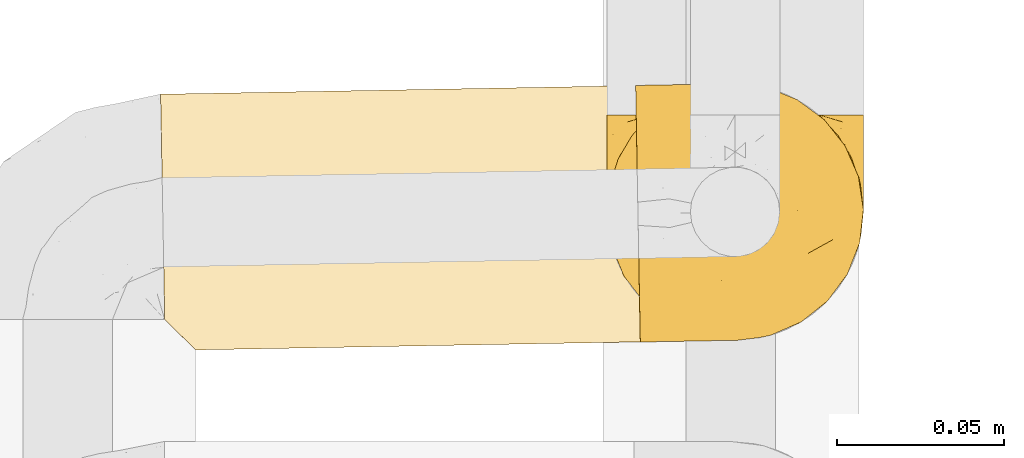
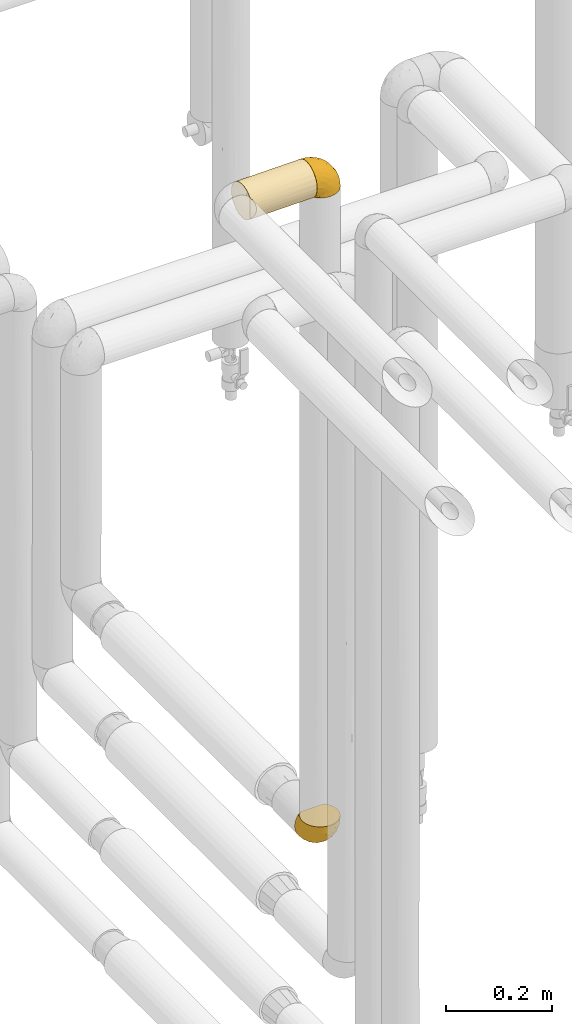
# One storey, part 71 of 827: 3 coverings.
"""IFC2X3 building model written with IfcOpenShell, lengths in millimetres."""

from ifc_helpers import new_model, entity, si_unit, converted_unit, derived_unit, direction, frame, origin, place, context, subcontext, project, spatial, faceted_brep, element, save


model = new_model("IFC2X3")

# Units and contexts
model_context = context("Model", 3, precision=0.01, world=origin(), true_north=direction((6.12303176911189e-17, 1.0)))
body_context = subcontext(model_context, "Body", "Model", "MODEL_VIEW")
ifc_project = project(units=[si_unit("LENGTHUNIT", "METRE", prefix="MILLI"), si_unit("AREAUNIT", "SQUARE_METRE"), si_unit("VOLUMEUNIT", "CUBIC_METRE"), converted_unit("PLANEANGLEUNIT", "DEGREE", entity("IfcRatioMeasure", 0.0174532925199433), si_unit("PLANEANGLEUNIT", "RADIAN"), dimensions=[0, 0, 0, 0, 0, 0, 0]), si_unit("MASSUNIT", "GRAM", prefix="KILO"), derived_unit("MASSDENSITYUNIT", [(si_unit("MASSUNIT", "GRAM", prefix="KILO"), 1), (si_unit("LENGTHUNIT", "METRE"), -3)]), derived_unit("MOMENTOFINERTIAUNIT", [(si_unit("LENGTHUNIT", "METRE"), 4)]), si_unit("TIMEUNIT", "SECOND"), si_unit("FREQUENCYUNIT", "HERTZ"), si_unit("THERMODYNAMICTEMPERATUREUNIT", "DEGREE_CELSIUS"), derived_unit("THERMALTRANSMITTANCEUNIT", [(si_unit("MASSUNIT", "GRAM", prefix="KILO"), 1), (si_unit("THERMODYNAMICTEMPERATUREUNIT", "KELVIN"), -1), (si_unit("TIMEUNIT", "SECOND"), -3)]), derived_unit("VOLUMETRICFLOWRATEUNIT", [(si_unit("LENGTHUNIT", "METRE"), 3), (si_unit("TIMEUNIT", "SECOND"), -1)]), derived_unit("MASSFLOWRATEUNIT", [(si_unit("MASSUNIT", "GRAM", prefix="KILO"), 1), (si_unit("TIMEUNIT", "SECOND"), -1)]), derived_unit("ROTATIONALFREQUENCYUNIT", [(si_unit("TIMEUNIT", "SECOND"), -1)]), si_unit("ELECTRICCURRENTUNIT", "AMPERE"), si_unit("ELECTRICVOLTAGEUNIT", "VOLT"), si_unit("POWERUNIT", "WATT"), si_unit("FORCEUNIT", "NEWTON", prefix="KILO"), si_unit("ILLUMINANCEUNIT", "LUX"), si_unit("LUMINOUSFLUXUNIT", "LUMEN"), si_unit("LUMINOUSINTENSITYUNIT", "CANDELA"), derived_unit("USERDEFINED", [(si_unit("MASSUNIT", "GRAM", prefix="KILO"), -1), (si_unit("LENGTHUNIT", "METRE"), -2), (si_unit("TIMEUNIT", "SECOND"), 3), (si_unit("LUMINOUSFLUXUNIT", "LUMEN"), 1)]), derived_unit("LINEARVELOCITYUNIT", [(si_unit("LENGTHUNIT", "METRE"), 1), (si_unit("TIMEUNIT", "SECOND"), -1)]), si_unit("PRESSUREUNIT", "PASCAL"), derived_unit("USERDEFINED", [(si_unit("LENGTHUNIT", "METRE"), -2), (si_unit("MASSUNIT", "GRAM", prefix="KILO"), 1), (si_unit("TIMEUNIT", "SECOND"), -2)]), derived_unit("LINEARFORCEUNIT", [(si_unit("MASSUNIT", "GRAM", prefix="KILO"), 1), (si_unit("LENGTHUNIT", "METRE"), 1), (si_unit("TIMEUNIT", "SECOND"), -2), (si_unit("LENGTHUNIT", "METRE"), -1)]), derived_unit("PLANARFORCEUNIT", [(si_unit("MASSUNIT", "GRAM", prefix="KILO"), 1), (si_unit("LENGTHUNIT", "METRE"), 1), (si_unit("TIMEUNIT", "SECOND"), -2), (si_unit("LENGTHUNIT", "METRE"), -2)])], contexts=[model_context])

# Site, building, storey
site_placement = place(None, origin())
site = spatial("IfcSite", under=ifc_project, at=site_placement, CompositionType="ELEMENT")
building_placement = place(site_placement, origin())
building = spatial("IfcBuilding", under=site, at=building_placement, CompositionType="ELEMENT")
storey_placement = place(building_placement, frame((0.0, 0.0, 28200.0)))
storey = spatial("IfcBuildingStorey", under=building, at=storey_placement, Name="08", CompositionType="ELEMENT", Elevation=28200.0)

# Coverings
covering_1_placement = place(storey_placement, frame((17888.48, 10823.39, 1308.2)))
element("IfcCovering", 1, at=covering_1_placement, inside=storey, Name=":ADSK_", ObjectType=":ADSK_", PredefinedType="INSULATION", context=body_context, shape_type="Brep", body=[
    faceted_brep([(74.68, 69.15, 23.36), (70.1, 69.15, 16.07), (64.01, 69.15, 9.98), (56.72, 69.15, 5.4), (48.6, 69.15, 2.56), (40.05, 69.15, 1.6), (31.49, 69.15, 2.56), (23.36, 69.15, 5.41), (16.07, 69.15, 9.99), (9.98, 69.15, 16.08), (5.4, 69.15, 23.37), (2.56, 69.15, 31.49), (1.6, 69.15, 40.05), (2.46, 69.15, 48.15), (5.01, 69.15, 55.88), (9.13, 69.15, 62.9), (14.62, 69.15, 68.89), (16.82, 69.15, 68.89), (18.56, 69.15, 68.89), (20.52, 69.15, 68.89), (22.49, 69.15, 68.89), (24.46, 69.15, 68.89), (26.42, 69.15, 68.89), (28.39, 69.15, 68.89), (30.36, 69.15, 68.89), (32.55, 69.15, 68.89), (34.75, 69.15, 68.89), (36.94, 69.15, 68.89), (39.13, 69.15, 68.89), (41.33, 69.15, 68.89), (43.52, 69.15, 68.89), (45.72, 69.15, 68.89), (47.91, 69.15, 68.89), (50.11, 69.15, 68.89), (52.3, 69.15, 68.89), (54.49, 69.15, 68.89), (56.69, 69.15, 68.89), (58.88, 69.15, 68.89), (61.08, 69.15, 68.89), (63.27, 69.15, 68.89), (65.47, 69.15, 68.89), (70.97, 69.15, 62.89), (75.09, 69.15, 55.86), (77.64, 69.15, 48.13), (78.5, 69.15, 40.05), (77.53, 69.15, 31.49), (14.62, 68.89, 69.15), (9.12, 62.89, 69.15), (5.0, 55.87, 69.15), (2.46, 48.14, 69.15), (1.6, 40.05, 69.15), (2.91, 30.09, 69.15), (6.75, 20.82, 69.15), (12.86, 12.86, 69.15), (20.82, 6.75, 69.15), (30.09, 2.91, 69.15), (40.05, 1.6, 69.15), (50.0, 2.91, 69.15), (59.27, 6.75, 69.15), (67.23, 12.86, 69.15), (73.34, 20.82, 69.15), (77.19, 30.09, 69.15), (78.5, 40.05, 69.15), (77.63, 48.14, 69.15), (75.09, 55.87, 69.15), (70.97, 62.89, 69.15), (65.47, 68.89, 69.15), (63.27, 68.89, 69.15), (62.29, 68.89, 69.15), (60.7, 68.89, 69.15), (59.11, 68.89, 69.15), (57.52, 68.89, 69.15), (55.93, 68.89, 69.15), (54.34, 68.89, 69.15), (52.76, 68.89, 69.15), (51.17, 68.89, 69.15), (49.58, 68.89, 69.15), (47.99, 68.89, 69.15), (46.4, 68.89, 69.15), (44.81, 68.89, 69.15), (43.22, 68.89, 69.15), (41.63, 68.89, 69.15), (40.05, 68.89, 69.15), (38.46, 68.89, 69.15), (36.87, 68.89, 69.15), (35.28, 68.89, 69.15), (33.69, 68.89, 69.15), (32.1, 68.89, 69.15), (30.51, 68.89, 69.15), (28.92, 68.89, 69.15), (27.33, 68.89, 69.15), (25.37, 68.89, 69.15), (23.4, 68.89, 69.15), (21.21, 68.89, 69.15), (19.01, 68.89, 69.15), (16.82, 68.89, 69.15), (42.32, 68.97, 68.96), (44.02, 68.96, 68.97), (47.13, 68.97, 68.97), (48.74, 68.97, 68.97), (23.57, 68.98, 68.95), (25.13, 68.97, 68.96), (61.34, 68.96, 68.98), (22.02, 68.96, 68.97), (29.72, 68.96, 68.97), (56.73, 68.96, 68.98), (55.14, 68.96, 68.97), (37.66, 68.96, 68.97), (64.12, 69.0, 68.94), (28.13, 68.96, 68.98), (26.62, 68.96, 68.98), (31.46, 68.97, 68.96), (16.16, 68.96, 68.97), (39.16, 68.96, 68.98), (50.37, 68.96, 68.98), (17.69, 68.97, 68.97), (19.17, 68.97, 68.96), (62.78, 68.97, 68.97), (58.35, 68.96, 68.97), (45.53, 68.96, 68.98), (59.91, 68.97, 68.96), (65.47, 68.97, 68.97), (65.47, 69.02, 68.94), (65.47, 69.08, 68.92), (14.62, 68.97, 68.97), (14.62, 68.94, 69.02), (14.62, 68.92, 69.08), (20.59, 68.96, 68.98), (32.99, 68.96, 68.97), (34.48, 68.95, 68.98), (51.91, 68.96, 68.97), (65.47, 68.92, 69.08), (65.47, 68.94, 69.02), (53.48, 68.98, 68.96), (14.62, 69.08, 68.92), (14.62, 69.02, 68.94), (40.77, 68.96, 68.97), (35.97, 68.97, 68.96), (7.84, 61.33, 67.02), (3.53, 53.1, 63.33), (8.32, 63.33, 64.61), (2.19, 55.53, 51.4), (3.53, 63.33, 53.1), (1.6, 54.6, 43.94), (1.6, 41.99, 61.87), (4.57, 57.07, 61.54), (3.96, 57.95, 57.95), (2.28, 51.56, 56.12), (1.6, 41.58, 63.4), (7.69, 61.7, 65.41), (8.32, 65.0, 63.04), (7.84, 67.02, 61.33), (1.6, 61.87, 41.99), (1.6, 49.27, 49.27), (1.6, 43.94, 54.6), (4.34, 61.21, 56.6), (1.6, 63.4, 41.58), (29.63, 33.11, 13.72), (27.34, 52.82, 5.82), (40.05, 43.3, 6.74), (2.39, 33.73, 58.82), (2.43, 36.52, 51.58), (9.07, 24.87, 42.09), (16.64, 14.17, 46.12), (9.54, 18.43, 55.56), (4.52, 28.67, 52.38), (4.52, 26.0, 61.54), (7.49, 49.25, 23.76), (7.49, 59.72, 20.5), (12.85, 55.1, 14.64), (2.35, 44.72, 41.77), (22.66, 34.15, 16.28), (32.9, 5.25, 49.4), (25.33, 6.75, 52.34), (40.05, 55.54, 4.3), (16.64, 10.47, 58.67), (19.99, 25.49, 25.26), (16.37, 35.53, 20.17), (3.26, 48.22, 34.7), (3.75, 58.71, 28.67), (19.58, 57.42, 8.62), (7.5, 34.84, 33.37), (4.04, 36.87, 41.35), (13.94, 45.01, 17.15), (19.58, 44.4, 12.68), (28.21, 23.96, 21.47), (24.75, 11.2, 41.11), (31.42, 10.56, 37.53), (26.2, 16.81, 30.64), (33.36, 17.38, 26.66), (40.05, 21.38, 21.38), (40.05, 32.34, 14.06), (40.05, 4.3, 55.54), (16.14, 20.65, 35.17), (12.85, 29.66, 29.04), (10.47, 39.6, 24.34), (6.49, 42.55, 29.33), (40.05, 6.74, 43.3), (40.05, 14.06, 32.34), (75.57, 26.84, 57.75), (47.37, 5.28, 49.41), (52.91, 18.52, 27.85), (50.46, 33.13, 13.7), (67.23, 55.1, 14.63), (60.5, 57.43, 8.61), (70.55, 20.72, 48.85), (63.45, 11.46, 54.13), (62.61, 17.69, 37.84), (72.6, 49.26, 23.75), (72.6, 59.73, 20.49), (76.34, 58.71, 28.66), (59.34, 29.72, 20.83), (77.76, 35.35, 55.15), (78.5, 43.94, 54.6), (78.5, 41.99, 61.87), (78.5, 63.4, 41.58), (53.16, 4.93, 57.58), (70.55, 17.46, 59.91), (48.88, 10.94, 36.94), (54.76, 8.92, 45.72), (52.74, 52.83, 5.82), (71.93, 29.34, 37.91), (75.79, 30.26, 50.18), (60.5, 44.4, 12.67), (77.86, 39.06, 49.29), (77.64, 43.06, 42.64), (78.5, 54.6, 43.94), (78.5, 49.27, 49.27), (67.23, 42.69, 19.45), (76.82, 48.2, 34.7), (78.5, 61.87, 41.99), (77.8, 33.44, 62.29), (67.23, 29.67, 29.01), (73.2, 38.5, 31.47), (67.66, 23.35, 37.18), (75.99, 34.97, 43.45), (76.57, 53.1, 63.33), (73.21, 59.68, 67.23), (71.93, 62.19, 66.07), (71.07, 64.11, 65.22), (75.09, 57.97, 61.99), (76.13, 57.95, 57.95), (76.57, 63.33, 53.09), (77.69, 51.77, 56.84), (72.26, 67.02, 61.33), (71.77, 64.98, 63.06), (77.9, 55.53, 51.41), (75.75, 61.22, 56.61)], [[[0, 1, 2, 3, 4, 5, 6, 7, 8, 9, 10, 11, 12, 13, 14, 15, 16, 17, 18, 19, 20, 21, 22, 23, 24, 25, 26, 27, 28, 29, 30, 31, 32, 33, 34, 35, 36, 37, 38, 39, 40, 41, 42, 43, 44, 45]], [[46, 47, 48, 49, 50, 51, 52, 53, 54, 55, 56, 57, 58, 59, 60, 61, 62, 63, 64, 65, 66, 67, 68, 69, 70, 71, 72, 73, 74, 75, 76, 77, 78, 79, 80, 81, 82, 83, 84, 85, 86, 87, 88, 89, 90, 91, 92, 93, 94, 95]], [[96, 97, 30]], [[98, 77, 99]], [[100, 101, 21]], [[69, 68, 102]], [[20, 19, 103]], [[24, 23, 104]], [[20, 103, 100]], [[72, 105, 106]], [[84, 83, 107]], [[89, 88, 104]], [[108, 67, 66]], [[109, 110, 90]], [[111, 25, 24]], [[112, 17, 16]], [[82, 113, 83]], [[109, 23, 22]], [[114, 76, 75]], [[105, 36, 106]], [[104, 111, 24]], [[18, 115, 116]], [[97, 96, 80]], [[67, 108, 117]], [[105, 71, 118]], [[31, 97, 119]], [[102, 120, 69]], [[108, 121, 122, 123, 40]], [[112, 95, 115]], [[17, 115, 18]], [[94, 116, 115]], [[117, 68, 67]], [[38, 117, 39]], [[112, 124, 125, 126, 46]], [[17, 112, 115]], [[70, 120, 118]], [[39, 117, 108]], [[120, 38, 37]], [[120, 37, 118]], [[120, 70, 69]], [[116, 94, 127]], [[128, 86, 129]], [[117, 38, 102]], [[74, 130, 75]], [[99, 33, 32]], [[115, 95, 94]], [[39, 108, 40]], [[108, 66, 131, 132, 121]], [[105, 72, 71]], [[118, 37, 36]], [[71, 70, 118]], [[35, 106, 36]], [[36, 105, 118]], [[35, 133, 106]], [[74, 73, 133]], [[106, 133, 73]], [[99, 114, 33]], [[133, 35, 34]], [[73, 72, 106]], [[95, 112, 46]], [[112, 16, 134, 135, 124]], [[130, 114, 75]], [[99, 76, 114]], [[114, 130, 33]], [[34, 33, 130]], [[78, 77, 98]], [[98, 119, 78]], [[130, 133, 34]], [[133, 130, 74]], [[79, 97, 80]], [[98, 99, 32]], [[98, 32, 31]], [[77, 76, 99]], [[97, 79, 119]], [[136, 96, 29]], [[30, 97, 31]], [[136, 29, 28]], [[81, 80, 96]], [[29, 96, 30]], [[31, 119, 98]], [[119, 79, 78]], [[96, 136, 81]], [[82, 81, 136]], [[113, 107, 83]], [[84, 107, 137]], [[107, 27, 137]], [[113, 28, 107]], [[27, 107, 28]], [[85, 84, 137]], [[137, 27, 26]], [[113, 136, 28]], [[136, 113, 82]], [[109, 89, 104]], [[86, 85, 129]], [[89, 109, 90]], [[111, 87, 128]], [[26, 129, 137]], [[88, 111, 104]], [[25, 111, 128]], [[22, 110, 109]], [[23, 109, 104]], [[110, 91, 90]], [[100, 92, 101]], [[110, 22, 101]], [[91, 110, 101]], [[116, 19, 18]], [[111, 88, 87]], [[127, 103, 19]], [[25, 128, 26]], [[86, 128, 87]], [[128, 129, 26]], [[137, 129, 85]], [[120, 102, 38]], [[117, 102, 68]], [[91, 101, 92]], [[21, 101, 22]], [[93, 92, 103]], [[100, 21, 20]], [[100, 103, 92]], [[127, 93, 103]], [[93, 127, 94]], [[116, 127, 19]], [[126, 138, 47]], [[48, 138, 139]], [[140, 125, 124]], [[141, 142, 143]], [[144, 49, 139]], [[145, 140, 146]], [[48, 139, 49]], [[139, 145, 147]], [[49, 144, 148, 50]], [[126, 125, 149]], [[14, 13, 142]], [[150, 146, 140]], [[149, 140, 145]], [[151, 150, 135]], [[151, 14, 142]], [[16, 15, 134]], [[13, 152, 142]], [[124, 150, 140]], [[141, 143, 153]], [[14, 151, 15]], [[15, 151, 134]], [[47, 46, 126]], [[139, 154, 144]], [[138, 48, 47]], [[125, 140, 149]], [[135, 134, 151]], [[146, 155, 141]], [[145, 146, 147]], [[149, 139, 138]], [[147, 153, 154]], [[147, 146, 141]], [[139, 147, 154]], [[139, 149, 145]], [[149, 138, 126]], [[147, 141, 153]], [[146, 150, 155]], [[151, 155, 150]], [[142, 141, 155]], [[13, 12, 156, 152]], [[152, 143, 142]], [[151, 142, 155]], [[150, 124, 135]], [[157, 158, 159]], [[160, 154, 161]], [[162, 163, 164]], [[165, 166, 160]], [[167, 168, 169]], [[153, 170, 161]], [[156, 12, 11]], [[158, 157, 171]], [[172, 55, 173]], [[158, 6, 174]], [[175, 54, 53]], [[52, 166, 164]], [[52, 164, 53]], [[54, 175, 173]], [[166, 52, 51]], [[176, 177, 171]], [[178, 143, 179]], [[156, 11, 179]], [[8, 7, 180]], [[169, 9, 8]], [[179, 143, 152, 156]], [[179, 11, 10]], [[168, 179, 10]], [[181, 162, 182]], [[179, 167, 178]], [[183, 184, 177]], [[183, 169, 184]], [[176, 171, 185]], [[172, 186, 187]], [[158, 7, 6]], [[159, 158, 174]], [[184, 180, 158]], [[54, 173, 55]], [[180, 169, 8]], [[188, 189, 187]], [[9, 168, 10]], [[186, 188, 187]], [[190, 157, 159, 191]], [[55, 172, 192]], [[176, 193, 194]], [[161, 170, 182]], [[162, 164, 165]], [[175, 164, 163]], [[51, 50, 148]], [[167, 195, 196]], [[178, 182, 170]], [[6, 5, 174]], [[158, 180, 7]], [[169, 180, 184]], [[169, 168, 9]], [[179, 168, 167]], [[182, 162, 165]], [[162, 194, 193]], [[161, 165, 160]], [[195, 181, 196]], [[192, 172, 197]], [[192, 56, 55]], [[189, 190, 198]], [[198, 197, 187]], [[172, 187, 197]], [[185, 189, 188]], [[198, 187, 189]], [[186, 172, 173]], [[173, 163, 186]], [[193, 186, 163]], [[176, 185, 188]], [[185, 157, 190]], [[188, 186, 193]], [[177, 176, 194]], [[188, 193, 176]], [[162, 193, 163]], [[195, 177, 194]], [[171, 177, 184]], [[181, 195, 194]], [[183, 167, 169]], [[162, 181, 194]], [[196, 182, 178]], [[158, 171, 184]], [[171, 157, 185]], [[177, 195, 183]], [[167, 183, 195]], [[182, 196, 181]], [[178, 170, 143]], [[178, 167, 196]], [[164, 175, 53]], [[173, 175, 163]], [[160, 51, 148]], [[164, 166, 165]], [[51, 160, 166]], [[160, 148, 144, 154]], [[153, 161, 154]], [[182, 165, 161]], [[190, 189, 185]], [[143, 170, 153]], [[60, 199, 61]], [[197, 200, 192]], [[201, 190, 202]], [[200, 57, 192]], [[203, 204, 2]], [[205, 206, 207]], [[208, 209, 210]], [[211, 207, 201]], [[212, 213, 214]], [[45, 215, 210]], [[216, 206, 58]], [[45, 44, 215]], [[59, 217, 60]], [[60, 217, 199]], [[0, 45, 210]], [[218, 201, 219]], [[202, 159, 220]], [[205, 221, 222]], [[223, 204, 203]], [[1, 203, 2]], [[57, 200, 216]], [[220, 3, 204]], [[220, 174, 4]], [[1, 0, 209]], [[212, 224, 213]], [[225, 226, 227]], [[228, 223, 203]], [[208, 210, 229]], [[210, 226, 229]], [[3, 220, 4]], [[58, 206, 59]], [[209, 203, 1]], [[202, 220, 223]], [[228, 203, 208]], [[202, 211, 201]], [[3, 2, 204]], [[202, 190, 191, 159]], [[210, 215, 230, 226]], [[199, 212, 231]], [[232, 233, 221]], [[233, 208, 229]], [[207, 206, 219]], [[217, 206, 205]], [[227, 224, 225]], [[233, 232, 228]], [[201, 207, 219]], [[234, 232, 221]], [[218, 219, 200]], [[202, 223, 211]], [[174, 220, 159]], [[174, 5, 4]], [[61, 231, 62]], [[220, 204, 223]], [[210, 209, 0]], [[203, 209, 208]], [[225, 233, 229]], [[224, 227, 213]], [[221, 233, 235]], [[57, 56, 192]], [[198, 218, 197]], [[200, 219, 216]], [[201, 198, 190]], [[197, 218, 200]], [[198, 201, 218]], [[206, 216, 219]], [[58, 57, 216]], [[231, 212, 214]], [[222, 212, 199]], [[228, 211, 223]], [[207, 211, 232]], [[62, 231, 214]], [[199, 231, 61]], [[233, 228, 208]], [[211, 228, 232]], [[222, 221, 235]], [[234, 205, 207]], [[206, 217, 59]], [[199, 217, 205]], [[205, 222, 199]], [[224, 222, 235]], [[222, 224, 212]], [[224, 235, 225]], [[233, 225, 235]], [[226, 225, 229]], [[205, 234, 221]], [[207, 232, 234]], [[63, 214, 236]], [[214, 213, 236]], [[214, 63, 62]], [[237, 236, 238]], [[238, 132, 131]], [[236, 237, 64]], [[239, 240, 241]], [[63, 236, 64]], [[131, 66, 65]], [[237, 131, 65]], [[242, 230, 43]], [[237, 65, 64]], [[239, 121, 132]], [[42, 242, 43]], [[241, 240, 243]], [[41, 123, 244]], [[43, 230, 215, 44]], [[244, 122, 245]], [[227, 246, 243]], [[241, 243, 246]], [[121, 239, 245]], [[41, 40, 123]], [[132, 238, 239]], [[244, 42, 41]], [[131, 237, 238]], [[240, 239, 238]], [[245, 239, 241]], [[247, 241, 246]], [[247, 244, 245]], [[238, 236, 240]], [[243, 236, 213]], [[236, 243, 240]], [[226, 246, 227]], [[243, 213, 227]], [[226, 242, 246]], [[241, 247, 245]], [[246, 242, 247]], [[244, 247, 242]], [[242, 226, 230]], [[42, 244, 242]], [[122, 244, 123]], [[122, 121, 245]]]),
])
covering_2_placement = place(storey_placement, frame((17754.8, 10820.5, 2810.11)))
element("IfcCovering", 2, at=covering_2_placement, inside=storey, Name=":ADSK_", ObjectType=":ADSK_", PredefinedType="INSULATION", context=body_context, shape_type="Brep", body=[
    faceted_brep([(143.99, 77.31, 23.98), (143.95, 79.92, 31.79), (143.93, 80.8, 39.99), (143.96, 79.5, 49.93), (144.03, 75.66, 59.19), (144.14, 69.56, 67.15), (144.29, 61.61, 73.25), (144.45, 52.35, 77.09), (144.64, 42.41, 78.39), (144.82, 32.47, 77.09), (144.98, 23.21, 73.25), (145.13, 15.26, 67.15), (145.24, 9.16, 59.19), (145.31, 5.32, 49.93), (145.33, 4.02, 39.99), (145.31, 4.9, 31.79), (145.26, 7.51, 23.98), (145.18, 11.73, 16.91), (145.08, 17.36, 10.89), (144.17, 67.46, 10.89), (144.07, 73.09, 16.91), (1.62, 76.91, 30.07), (1.69, 73.07, 20.81), (1.8, 66.97, 12.86), (1.94, 59.02, 6.76), (2.11, 49.76, 2.92), (2.29, 39.82, 1.61), (2.44, 31.62, 2.5), (2.58, 23.81, 5.11), (2.71, 16.74, 9.33), (2.82, 10.73, 14.96), (2.83, 10.73, 65.07), (2.72, 16.74, 70.7), (2.59, 23.81, 74.91), (2.45, 31.62, 77.53), (2.3, 39.82, 78.41), (2.12, 49.76, 77.1), (1.95, 59.02, 73.27), (1.8, 66.97, 67.17), (1.69, 73.07, 59.21), (1.62, 76.91, 49.95), (1.6, 78.22, 40.01), (11.52, 2.19, 33.22), (9.72, 3.95, 26.65), (6.79, 6.83, 20.49), (12.12, 1.6, 40.01), (141.01, 22.83, 6.92), (137.97, 28.92, 3.99), (136.06, 35.47, 2.2), (135.33, 42.24, 1.6), (135.81, 49.04, 2.2), (137.48, 55.65, 3.99), (140.3, 61.85, 6.92), (6.8, 6.83, 59.53), (9.72, 3.95, 53.37), (11.52, 2.19, 46.8)], [[[0, 1, 2, 3, 4, 5, 6, 7, 8, 9, 10, 11, 12, 13, 14, 15, 16, 17, 18, 19, 20]], [[21, 22, 23, 24, 25, 26, 27, 28, 29, 30, 31, 32, 33, 34, 35, 36, 37, 38, 39, 40, 41]], [[42, 43, 15]], [[44, 30, 17]], [[43, 44, 16]], [[45, 42, 14]], [[15, 14, 42]], [[43, 16, 15]], [[44, 17, 16]], [[30, 18, 17]], [[46, 29, 28]], [[47, 28, 27]], [[48, 27, 26]], [[46, 18, 29]], [[48, 47, 27]], [[49, 48, 26]], [[46, 28, 47]], [[29, 18, 30]], [[50, 49, 26]], [[50, 26, 25]], [[51, 25, 24]], [[51, 50, 25]], [[19, 52, 24]], [[51, 24, 52]], [[24, 23, 19]], [[20, 23, 22]], [[0, 22, 21]], [[1, 21, 41]], [[20, 22, 0]], [[0, 21, 1]], [[41, 2, 1]], [[23, 20, 19]], [[3, 2, 41, 40]], [[4, 3, 40, 39]], [[39, 38, 5, 4]], [[7, 6, 37, 36]], [[8, 7, 36, 35]], [[38, 37, 6, 5]], [[8, 35, 34]], [[9, 34, 33]], [[10, 33, 32]], [[8, 34, 9]], [[9, 33, 10]], [[32, 11, 10]], [[32, 31, 11]], [[31, 53, 12]], [[54, 55, 13]], [[53, 54, 12]], [[12, 54, 13]], [[14, 13, 55]], [[45, 14, 55]], [[31, 12, 11]], [[48, 49, 50, 51, 52, 19, 18, 46, 47]], [[30, 44, 43, 42, 45, 55, 54, 53, 31]]]),
])
covering_3_placement = place(storey_placement, frame((17897.14, 10822.87, 2819.41)))
element("IfcCovering", 3, at=covering_3_placement, inside=storey, Name=":ADSK_", ObjectType=":ADSK_", PredefinedType="INSULATION", context=body_context, shape_type="Brep", body=[
    faceted_brep([(2.93, 5.41, 47.38), (2.84, 9.99, 54.67), (2.73, 16.08, 60.76), (2.6, 23.36, 65.34), (2.45, 31.49, 68.18), (2.3, 40.04, 69.15), (2.14, 48.6, 68.18), (2.0, 56.73, 65.33), (1.86, 64.01, 60.75), (1.75, 70.1, 54.66), (1.67, 74.68, 47.37), (1.61, 77.52, 39.25), (1.6, 78.48, 30.7), (1.61, 77.62, 22.59), (1.66, 75.07, 14.86), (1.73, 70.95, 7.84), (1.83, 65.46, 1.85), (1.87, 63.26, 1.85), (1.9, 61.52, 1.85), (1.94, 59.56, 1.85), (1.97, 57.59, 1.85), (2.01, 55.62, 1.85), (2.04, 53.66, 1.85), (2.08, 51.69, 1.85), (2.11, 49.73, 1.85), (2.15, 47.53, 1.85), (2.19, 45.34, 1.85), (2.23, 43.14, 1.85), (2.27, 40.95, 1.85), (2.31, 38.76, 1.85), (2.35, 36.56, 1.85), (2.39, 34.37, 1.85), (2.43, 32.17, 1.85), (2.47, 29.98, 1.85), (2.51, 27.79, 1.85), (2.55, 25.59, 1.85), (2.59, 23.4, 1.85), (2.63, 21.2, 1.85), (2.67, 19.01, 1.85), (2.71, 16.82, 1.85), (2.75, 14.62, 1.85), (2.85, 9.12, 7.85), (2.93, 5.0, 14.88), (2.98, 2.46, 22.61), (2.99, 1.6, 30.7), (2.98, 2.56, 39.26), (2.08, 65.46, 1.6), (7.98, 71.07, 1.6), (14.92, 75.32, 1.6), (22.61, 78.0, 1.6), (30.69, 79.01, 1.6), (40.66, 77.88, 1.6), (50.0, 74.21, 1.6), (58.08, 68.25, 1.6), (64.33, 60.39, 1.6), (68.34, 51.19, 1.6), (69.83, 41.27, 1.6), (68.7, 31.29, 1.6), (65.03, 21.95, 1.6), (59.06, 13.88, 1.6), (51.21, 7.62, 1.6), (42.01, 3.61, 1.6), (32.08, 2.12, 1.6), (23.98, 2.84, 1.6), (16.2, 5.24, 1.6), (9.1, 9.23, 1.6), (3.01, 14.63, 1.6), (2.97, 16.82, 1.6), (2.95, 17.8, 1.6), (2.92, 19.39, 1.6), (2.89, 20.98, 1.6), (2.86, 22.57, 1.6), (2.83, 24.16, 1.6), (2.8, 25.75, 1.6), (2.77, 27.33, 1.6), (2.75, 28.92, 1.6), (2.72, 30.51, 1.6), (2.69, 32.1, 1.6), (2.66, 33.69, 1.6), (2.63, 35.28, 1.6), (2.6, 36.87, 1.6), (2.57, 38.45, 1.6), (2.54, 40.04, 1.6), (2.51, 41.63, 1.6), (2.49, 43.22, 1.6), (2.46, 44.81, 1.6), (2.43, 46.4, 1.6), (2.4, 47.99, 1.6), (2.37, 49.57, 1.6), (2.34, 51.16, 1.6), (2.31, 52.75, 1.6), (2.28, 54.72, 1.6), (2.24, 56.68, 1.6), (2.2, 58.88, 1.6), (2.16, 61.07, 1.6), (2.12, 63.27, 1.6), (2.51, 37.77, 1.78), (2.55, 36.07, 1.77), (2.6, 32.96, 1.78), (2.63, 31.35, 1.77), (2.16, 56.51, 1.79), (2.19, 54.96, 1.78), (2.87, 18.75, 1.76), (2.15, 58.06, 1.77), (2.29, 50.37, 1.77), (2.78, 23.36, 1.76), (2.75, 24.95, 1.77), (2.43, 42.42, 1.77), (2.87, 15.97, 1.8), (2.26, 51.96, 1.76), (2.23, 53.46, 1.77), (2.31, 48.63, 1.78), (2.04, 63.93, 1.77), (2.46, 40.93, 1.77), (2.67, 29.72, 1.76), (2.06, 62.4, 1.77), (2.08, 60.91, 1.78), (2.88, 17.31, 1.77), (2.81, 21.74, 1.77), (2.58, 34.56, 1.77), (2.82, 20.18, 1.78), (2.93, 14.63, 1.77), (2.88, 14.62, 1.8), (2.82, 14.62, 1.82), (2.01, 65.46, 1.77), (2.03, 65.46, 1.72), (2.05, 65.46, 1.66), (2.13, 59.49, 1.76), (2.35, 47.1, 1.77), (2.38, 45.61, 1.76), (2.69, 28.18, 1.77), (2.98, 14.63, 1.66), (2.95, 14.63, 1.72), (2.7, 26.61, 1.78), (1.9, 65.46, 1.82), (1.95, 65.46, 1.8), (2.49, 39.32, 1.77), (2.39, 44.12, 1.78), (9.52, 72.39, 3.72), (17.67, 76.84, 7.41), (7.53, 71.87, 6.13), (16.14, 78.75, 26.8), (15.22, 78.14, 19.34), (7.44, 76.66, 17.64), (28.74, 78.98, 8.87), (13.72, 75.73, 9.2), (12.83, 76.33, 12.79), (19.19, 78.12, 14.62), (29.15, 78.98, 7.34), (9.15, 72.53, 5.33), (5.86, 71.84, 7.7), (3.83, 72.28, 9.41), (8.87, 78.61, 28.75), (21.47, 78.84, 21.47), (26.79, 78.94, 16.14), (9.58, 75.89, 14.14), (7.34, 78.59, 29.16), (38.14, 51.11, 57.02), (18.39, 53.04, 64.91), (28.14, 40.51, 64.0), (37.01, 78.33, 11.92), (34.22, 78.24, 19.16), (45.99, 71.81, 28.65), (56.83, 64.44, 24.62), (52.45, 71.46, 15.18), (42.12, 76.29, 18.36), (44.79, 76.34, 9.2), (21.59, 72.96, 46.98), (11.12, 72.76, 50.24), (15.85, 67.48, 56.1), (26.03, 78.17, 28.97), (36.98, 58.05, 54.45), (66.05, 48.35, 21.34), (64.41, 55.88, 18.4), (15.9, 40.29, 66.44), (60.53, 64.51, 12.07), (45.58, 60.88, 45.48), (35.47, 64.32, 50.56), (22.55, 77.19, 36.04), (12.06, 76.52, 42.07), (13.65, 60.71, 62.12), (36.01, 73.21, 37.37), (33.9, 76.63, 29.38), (25.96, 66.58, 53.59), (26.67, 60.95, 58.06), (47.26, 52.7, 49.26), (59.95, 56.39, 29.63), (60.71, 49.73, 33.21), (54.36, 54.83, 40.1), (53.93, 47.67, 44.07), (50.05, 40.91, 49.36), (39.1, 40.71, 56.68), (67.12, 41.22, 15.2), (50.35, 64.82, 35.57), (41.28, 67.95, 41.7), (31.3, 70.15, 46.39), (28.27, 74.07, 41.4), (64.69, 41.17, 27.44), (57.37, 41.04, 38.4), (45.23, 5.29, 12.99), (66.28, 33.87, 21.33), (53.15, 28.1, 42.89), (38.5, 30.29, 57.03), (16.83, 13.12, 56.11), (14.39, 19.8, 62.13), (51.26, 10.42, 21.89), (60.39, 17.68, 16.62), (54.15, 18.41, 32.9), (22.77, 7.85, 46.99), (12.31, 7.66, 50.25), (13.38, 3.94, 42.08), (42.06, 21.47, 49.91), (36.77, 2.94, 15.59), (28.19, 2.05, 16.14), (30.14, 2.09, 8.87), (8.73, 1.7, 29.16), (66.73, 28.1, 13.16), (54.52, 10.48, 10.83), (60.65, 32.26, 33.8), (62.78, 26.42, 25.02), (18.84, 27.64, 64.92), (42.67, 8.89, 32.82), (41.81, 5.0, 20.56), (27.41, 20.04, 58.07), (33.06, 2.77, 21.46), (29.05, 2.93, 28.1), (17.54, 1.86, 26.8), (22.86, 1.96, 21.47), (29.24, 13.34, 51.28), (23.9, 3.65, 36.04), (10.27, 1.73, 28.75), (38.67, 2.93, 8.45), (42.26, 13.58, 41.72), (33.54, 7.44, 39.27), (48.59, 13.26, 33.56), (37.11, 4.72, 27.29), (19.0, 3.82, 7.41), (12.35, 7.05, 3.51), (9.83, 8.29, 4.68), (7.89, 9.11, 5.52), (14.1, 5.21, 8.75), (14.14, 4.16, 12.79), (8.77, 3.63, 17.65), (20.34, 2.71, 13.9), (5.01, 7.87, 9.41), (7.04, 8.39, 7.68), (16.59, 2.44, 19.33), (10.87, 4.48, 14.13)], [[[0, 1, 2, 3, 4, 5, 6, 7, 8, 9, 10, 11, 12, 13, 14, 15, 16, 17, 18, 19, 20, 21, 22, 23, 24, 25, 26, 27, 28, 29, 30, 31, 32, 33, 34, 35, 36, 37, 38, 39, 40, 41, 42, 43, 44, 45]], [[46, 47, 48, 49, 50, 51, 52, 53, 54, 55, 56, 57, 58, 59, 60, 61, 62, 63, 64, 65, 66, 67, 68, 69, 70, 71, 72, 73, 74, 75, 76, 77, 78, 79, 80, 81, 82, 83, 84, 85, 86, 87, 88, 89, 90, 91, 92, 93, 94, 95]], [[96, 97, 30]], [[98, 77, 99]], [[100, 101, 21]], [[69, 68, 102]], [[20, 19, 103]], [[24, 23, 104]], [[20, 103, 100]], [[72, 105, 106]], [[84, 83, 107]], [[89, 88, 104]], [[108, 67, 66]], [[109, 110, 90]], [[111, 25, 24]], [[112, 17, 16]], [[82, 113, 83]], [[109, 23, 22]], [[114, 76, 75]], [[105, 36, 106]], [[104, 111, 24]], [[18, 115, 116]], [[97, 96, 80]], [[67, 108, 117]], [[105, 71, 118]], [[31, 97, 119]], [[102, 120, 69]], [[108, 121, 122, 123, 40]], [[112, 95, 115]], [[17, 115, 18]], [[94, 116, 115]], [[117, 68, 67]], [[38, 117, 39]], [[112, 124, 125, 126, 46]], [[17, 112, 115]], [[70, 120, 118]], [[39, 117, 108]], [[120, 38, 37]], [[120, 37, 118]], [[120, 70, 69]], [[116, 94, 127]], [[128, 86, 129]], [[117, 38, 102]], [[74, 130, 75]], [[99, 33, 32]], [[115, 95, 94]], [[39, 108, 40]], [[108, 66, 131, 132, 121]], [[105, 72, 71]], [[118, 37, 36]], [[71, 70, 118]], [[35, 106, 36]], [[36, 105, 118]], [[35, 133, 106]], [[74, 73, 133]], [[106, 133, 73]], [[99, 114, 33]], [[133, 35, 34]], [[73, 72, 106]], [[95, 112, 46]], [[112, 16, 134, 135, 124]], [[130, 114, 75]], [[99, 76, 114]], [[114, 130, 33]], [[34, 33, 130]], [[78, 77, 98]], [[98, 119, 78]], [[130, 133, 34]], [[133, 130, 74]], [[79, 97, 80]], [[98, 99, 32]], [[98, 32, 31]], [[77, 76, 99]], [[97, 79, 119]], [[136, 96, 29]], [[30, 97, 31]], [[136, 29, 28]], [[81, 80, 96]], [[29, 96, 30]], [[31, 119, 98]], [[119, 79, 78]], [[96, 136, 81]], [[82, 81, 136]], [[113, 107, 83]], [[84, 107, 137]], [[107, 27, 137]], [[113, 28, 107]], [[27, 107, 28]], [[85, 84, 137]], [[137, 27, 26]], [[113, 136, 28]], [[136, 113, 82]], [[109, 89, 104]], [[86, 85, 129]], [[89, 109, 90]], [[111, 87, 128]], [[26, 129, 137]], [[88, 111, 104]], [[25, 111, 128]], [[22, 110, 109]], [[23, 109, 104]], [[110, 91, 90]], [[100, 92, 101]], [[110, 22, 101]], [[91, 110, 101]], [[116, 19, 18]], [[111, 88, 87]], [[127, 103, 19]], [[25, 128, 26]], [[86, 128, 87]], [[128, 129, 26]], [[137, 129, 85]], [[120, 102, 38]], [[117, 102, 68]], [[91, 101, 92]], [[21, 101, 22]], [[93, 92, 103]], [[100, 21, 20]], [[100, 103, 92]], [[127, 93, 103]], [[93, 127, 94]], [[116, 127, 19]], [[126, 138, 47]], [[48, 138, 139]], [[140, 125, 124]], [[141, 142, 143]], [[144, 49, 139]], [[145, 140, 146]], [[48, 139, 49]], [[139, 145, 147]], [[49, 144, 148, 50]], [[126, 125, 149]], [[14, 13, 143]], [[150, 146, 140]], [[149, 140, 145]], [[151, 150, 135]], [[151, 14, 143]], [[16, 15, 134]], [[13, 152, 143]], [[124, 150, 140]], [[142, 141, 153]], [[14, 151, 15]], [[15, 151, 134]], [[47, 46, 126]], [[139, 154, 144]], [[138, 48, 47]], [[125, 140, 149]], [[135, 134, 151]], [[146, 155, 142]], [[145, 146, 147]], [[149, 139, 138]], [[147, 153, 154]], [[147, 146, 142]], [[139, 147, 154]], [[139, 149, 145]], [[149, 138, 126]], [[155, 146, 150]], [[147, 142, 153]], [[151, 155, 150]], [[143, 142, 155]], [[13, 12, 156, 152]], [[152, 141, 143]], [[151, 143, 155]], [[150, 124, 135]], [[157, 158, 159]], [[160, 154, 161]], [[162, 163, 164]], [[165, 166, 160]], [[167, 168, 169]], [[153, 170, 161]], [[156, 12, 11]], [[158, 157, 171]], [[172, 55, 173]], [[158, 6, 174]], [[175, 54, 53]], [[52, 166, 164]], [[52, 164, 53]], [[54, 175, 173]], [[166, 52, 51]], [[176, 177, 171]], [[178, 141, 179]], [[156, 11, 179]], [[8, 7, 180]], [[169, 9, 8]], [[179, 141, 152, 156]], [[179, 11, 10]], [[168, 179, 10]], [[181, 162, 182]], [[179, 167, 178]], [[183, 184, 177]], [[183, 169, 184]], [[176, 171, 185]], [[172, 186, 187]], [[158, 7, 6]], [[159, 158, 174]], [[184, 180, 158]], [[54, 173, 55]], [[180, 169, 8]], [[188, 189, 187]], [[9, 168, 10]], [[186, 188, 187]], [[190, 157, 159, 191]], [[55, 172, 192]], [[176, 193, 194]], [[161, 170, 182]], [[51, 50, 148]], [[162, 164, 165]], [[175, 164, 163]], [[167, 195, 196]], [[178, 182, 170]], [[6, 5, 174]], [[158, 180, 7]], [[169, 180, 184]], [[169, 168, 9]], [[179, 168, 167]], [[182, 162, 165]], [[162, 194, 193]], [[161, 165, 160]], [[195, 181, 196]], [[192, 172, 197]], [[192, 56, 55]], [[189, 190, 198]], [[198, 197, 187]], [[172, 187, 197]], [[185, 189, 188]], [[198, 187, 189]], [[186, 172, 173]], [[173, 163, 186]], [[193, 186, 163]], [[176, 185, 188]], [[185, 157, 190]], [[188, 186, 193]], [[177, 176, 194]], [[188, 193, 176]], [[162, 193, 163]], [[195, 177, 194]], [[171, 177, 184]], [[181, 195, 194]], [[183, 167, 169]], [[162, 181, 194]], [[196, 182, 178]], [[158, 171, 184]], [[171, 157, 185]], [[177, 195, 183]], [[167, 183, 195]], [[182, 196, 181]], [[178, 170, 141]], [[178, 167, 196]], [[164, 175, 53]], [[173, 175, 163]], [[160, 51, 148]], [[164, 166, 165]], [[51, 160, 166]], [[160, 148, 144, 154]], [[153, 161, 154]], [[182, 165, 161]], [[190, 189, 185]], [[141, 170, 153]], [[60, 199, 61]], [[197, 200, 192]], [[201, 190, 202]], [[200, 57, 192]], [[203, 204, 2]], [[205, 206, 207]], [[208, 209, 210]], [[211, 207, 201]], [[212, 213, 214]], [[45, 215, 210]], [[216, 206, 58]], [[45, 44, 215]], [[59, 217, 60]], [[60, 217, 199]], [[0, 45, 210]], [[218, 201, 219]], [[202, 159, 220]], [[205, 221, 222]], [[223, 204, 203]], [[1, 203, 2]], [[57, 200, 216]], [[220, 3, 204]], [[220, 174, 4]], [[1, 0, 209]], [[212, 224, 213]], [[225, 226, 227]], [[228, 223, 203]], [[208, 210, 229]], [[210, 226, 229]], [[3, 220, 4]], [[58, 206, 59]], [[209, 203, 1]], [[202, 220, 223]], [[228, 203, 208]], [[202, 211, 201]], [[3, 2, 204]], [[202, 190, 191, 159]], [[210, 215, 230, 226]], [[199, 212, 231]], [[232, 233, 221]], [[233, 208, 229]], [[207, 206, 219]], [[217, 206, 205]], [[227, 224, 225]], [[233, 232, 228]], [[201, 207, 219]], [[234, 232, 221]], [[218, 219, 200]], [[202, 223, 211]], [[174, 220, 159]], [[174, 5, 4]], [[61, 231, 62]], [[220, 204, 223]], [[210, 209, 0]], [[203, 209, 208]], [[225, 233, 229]], [[224, 227, 213]], [[221, 233, 235]], [[57, 56, 192]], [[198, 218, 197]], [[200, 219, 216]], [[201, 198, 190]], [[197, 218, 200]], [[198, 201, 218]], [[206, 216, 219]], [[58, 57, 216]], [[231, 212, 214]], [[222, 212, 199]], [[228, 211, 223]], [[207, 211, 232]], [[62, 231, 214]], [[199, 231, 61]], [[233, 228, 208]], [[211, 228, 232]], [[222, 221, 235]], [[234, 205, 207]], [[206, 217, 59]], [[199, 217, 205]], [[205, 222, 199]], [[224, 222, 235]], [[222, 224, 212]], [[224, 235, 225]], [[233, 225, 235]], [[226, 225, 229]], [[205, 234, 221]], [[207, 232, 234]], [[63, 214, 236]], [[214, 213, 236]], [[214, 63, 62]], [[237, 236, 238]], [[238, 132, 131]], [[236, 237, 64]], [[239, 240, 241]], [[63, 236, 64]], [[131, 66, 65]], [[237, 131, 65]], [[242, 230, 43]], [[237, 65, 64]], [[239, 121, 132]], [[42, 242, 43]], [[241, 240, 243]], [[41, 123, 244]], [[43, 230, 215, 44]], [[244, 122, 245]], [[227, 246, 243]], [[245, 241, 247]], [[121, 239, 245]], [[41, 40, 123]], [[132, 238, 239]], [[244, 42, 41]], [[131, 237, 238]], [[240, 239, 238]], [[245, 239, 241]], [[247, 241, 246]], [[247, 244, 245]], [[238, 236, 240]], [[243, 236, 213]], [[236, 243, 240]], [[246, 241, 243]], [[243, 213, 227]], [[226, 242, 246]], [[227, 226, 246]], [[246, 242, 247]], [[244, 247, 242]], [[242, 226, 230]], [[42, 244, 242]], [[122, 244, 123]], [[122, 121, 245]]]),
])

save(model, "model.ifc")
